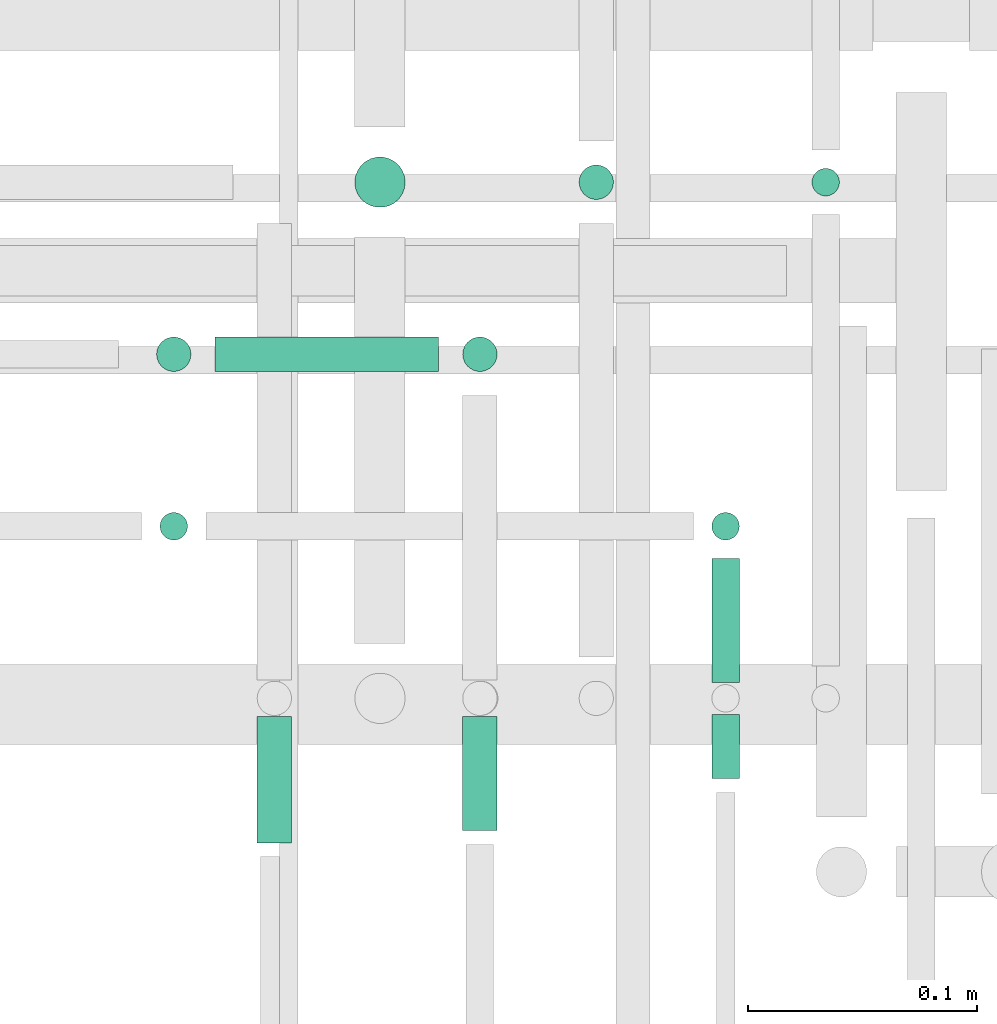
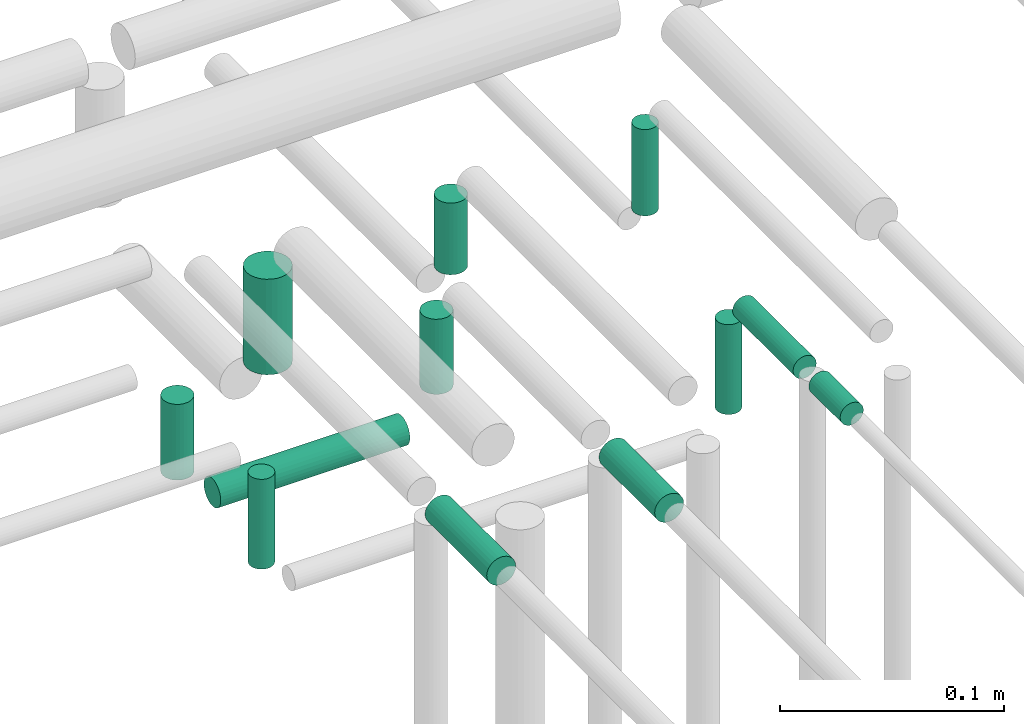
# One storey, part 298 of 331: 12 flow segments.
"""IFC2X3 building model written with IfcOpenShell, lengths in millimetres."""

from ifc_helpers import new_model, entity, si_unit, converted_unit, derived_unit, direction, frame, frame_2d, origin, origin_2d_with_axis, place, context, subcontext, project, spatial, circle, extrude, type_object, element, save


model = new_model("IFC2X3")

# Units and contexts
model_context = context("Model", 3, precision=0.01, world=origin(), true_north=direction((6.12303176911189e-17, 1.0)))
body_context = subcontext(model_context, "Body", "Model", "MODEL_VIEW")
ifc_project = project(units=[si_unit("LENGTHUNIT", "METRE", prefix="MILLI"), si_unit("AREAUNIT", "SQUARE_METRE"), si_unit("VOLUMEUNIT", "CUBIC_METRE"), converted_unit("PLANEANGLEUNIT", "DEGREE", entity("IfcRatioMeasure", 0.0174532925199433), si_unit("PLANEANGLEUNIT", "RADIAN"), dimensions=[0, 0, 0, 0, 0, 0, 0]), si_unit("MASSUNIT", "GRAM", prefix="KILO"), derived_unit("MASSDENSITYUNIT", [(si_unit("MASSUNIT", "GRAM", prefix="KILO"), 1), (si_unit("LENGTHUNIT", "METRE"), -3)]), derived_unit("MOMENTOFINERTIAUNIT", [(si_unit("LENGTHUNIT", "METRE"), 4)]), si_unit("TIMEUNIT", "SECOND"), si_unit("FREQUENCYUNIT", "HERTZ"), si_unit("THERMODYNAMICTEMPERATUREUNIT", "DEGREE_CELSIUS"), derived_unit("THERMALTRANSMITTANCEUNIT", [(si_unit("MASSUNIT", "GRAM", prefix="KILO"), 1), (si_unit("THERMODYNAMICTEMPERATUREUNIT", "KELVIN"), -1), (si_unit("TIMEUNIT", "SECOND"), -3)]), derived_unit("VOLUMETRICFLOWRATEUNIT", [(si_unit("LENGTHUNIT", "METRE"), 3), (si_unit("TIMEUNIT", "SECOND"), -1)]), derived_unit("MASSFLOWRATEUNIT", [(si_unit("MASSUNIT", "GRAM", prefix="KILO"), 1), (si_unit("TIMEUNIT", "SECOND"), -1)]), derived_unit("ROTATIONALFREQUENCYUNIT", [(si_unit("TIMEUNIT", "SECOND"), -1)]), si_unit("ELECTRICCURRENTUNIT", "AMPERE"), si_unit("ELECTRICVOLTAGEUNIT", "VOLT"), si_unit("POWERUNIT", "WATT"), si_unit("FORCEUNIT", "NEWTON", prefix="KILO"), si_unit("ILLUMINANCEUNIT", "LUX"), si_unit("LUMINOUSFLUXUNIT", "LUMEN"), si_unit("LUMINOUSINTENSITYUNIT", "CANDELA"), derived_unit("USERDEFINED", [(si_unit("MASSUNIT", "GRAM", prefix="KILO"), -1), (si_unit("LENGTHUNIT", "METRE"), -2), (si_unit("TIMEUNIT", "SECOND"), 3), (si_unit("LUMINOUSFLUXUNIT", "LUMEN"), 1)]), derived_unit("LINEARVELOCITYUNIT", [(si_unit("LENGTHUNIT", "METRE"), 1), (si_unit("TIMEUNIT", "SECOND"), -1)]), si_unit("PRESSUREUNIT", "PASCAL"), derived_unit("USERDEFINED", [(si_unit("LENGTHUNIT", "METRE"), -2), (si_unit("MASSUNIT", "GRAM", prefix="KILO"), 1), (si_unit("TIMEUNIT", "SECOND"), -2)]), derived_unit("LINEARFORCEUNIT", [(si_unit("MASSUNIT", "GRAM", prefix="KILO"), 1), (si_unit("LENGTHUNIT", "METRE"), 1), (si_unit("TIMEUNIT", "SECOND"), -2), (si_unit("LENGTHUNIT", "METRE"), -1)]), derived_unit("PLANARFORCEUNIT", [(si_unit("MASSUNIT", "GRAM", prefix="KILO"), 1), (si_unit("LENGTHUNIT", "METRE"), 1), (si_unit("TIMEUNIT", "SECOND"), -2), (si_unit("LENGTHUNIT", "METRE"), -2)])], contexts=[model_context])

# Site, building, storey
site_placement = place(None, frame((0.0, -0.00077364408347762, 0.0)))
site = spatial("IfcSite", under=ifc_project, at=site_placement, CompositionType="ELEMENT")
building_placement = place(site_placement, origin())
building = spatial("IfcBuilding", under=site, at=building_placement, CompositionType="ELEMENT")
storey_placement = place(building_placement, origin())
storey = spatial("IfcBuildingStorey", under=building, at=storey_placement, CompositionType="ELEMENT", Elevation=0.0)

# Flow segments
pipe_segment_type = type_object("IfcPipeSegmentType", PredefinedType="NOTDEFINED")
flow_segment_1_placement = place(storey_placement, frame((63502.5166110417, 8368.02529159144, 14489.0)))
element("IfcFlowSegment", 1, at=flow_segment_1_placement, inside=storey, type_object=pipe_segment_type, context=body_context, shape_type="SweptSolid", body=[
    extrude(circle(Radius=6.0, at=frame_2d((0.0, 1.08286712929839e-12), x_axis=(1.0, 0.0))), frame((7.59527223591454, 7.5952722359167, 0.0), z_axis=(0.0, 0.0, 1.0), x_axis=(-1.0, 0.0, 0.0)), (0.0, 0.0, 1.0), 47.0000000000153),
])
flow_segment_2_placement = place(storey_placement, frame((63458.8735189448, 8157.62056382736, 14542.4047277641)))
element("IfcFlowSegment", 2, at=flow_segment_2_placement, inside=storey, type_object=pipe_segment_type, context=body_context, shape_type="SweptSolid", body=[
    extrude(circle(Radius=6.0, at=origin_2d_with_axis()), frame((7.59527223591454, 0.0, 7.5952722359167), z_axis=(0.0, 1.0, 0.0), x_axis=(-1.0, 0.0, 0.0)), (0.0, 0.0, 1.0), 53.9999999999996),
])
flow_segment_3_placement = place(storey_placement, frame((63458.8735189448, 8115.62056382737, 14542.4047277641)))
element("IfcFlowSegment", 3, at=flow_segment_3_placement, inside=storey, type_object=pipe_segment_type, context=body_context, shape_type="SweptSolid", body=[
    extrude(circle(Radius=6.0, at=frame_2d((-8.66293703438714e-12, 0.0), x_axis=(1.0, 0.0))), frame((7.5952722359232, 0.0, 7.5952722359167), z_axis=(0.0, 1.0, 0.0), x_axis=(-1.0, 0.0, 0.0)), (0.0, 0.0, 1.0), 27.9999999999828),
])
flow_segment_4_placement = place(storey_placement, frame((63218.3298174384, 8218.02529159144, 14487.090264591)))
element("IfcFlowSegment", 4, at=flow_segment_4_placement, inside=storey, type_object=pipe_segment_type, context=body_context, shape_type="SweptSolid", body=[
    extrude(circle(Radius=6.0, at=origin_2d_with_axis()), frame((7.59527223591454, 7.59527223591562, 0.0)), (0.0, 0.0, 1.0), 48.9097354090115),
])
flow_segment_5_placement = place(storey_placement, frame((63458.8735189448, 8218.02529159144, 14487.090264591)))
element("IfcFlowSegment", 5, at=flow_segment_5_placement, inside=storey, type_object=pipe_segment_type, context=body_context, shape_type="SweptSolid", body=[
    extrude(circle(Radius=6.0, at=origin_2d_with_axis()), frame((7.59527223591454, 7.59527223591562, 0.0)), (0.0, 0.0, 1.0), 48.9097354090028),
])
flow_segment_6_placement = place(storey_placement, frame((63401.0132627126, 8366.52529159144, 14493.0)))
element("IfcFlowSegment", 6, at=flow_segment_6_placement, inside=storey, type_object=pipe_segment_type, context=body_context, shape_type="SweptSolid", body=[
    extrude(circle(Radius=7.5, at=origin_2d_with_axis()), frame((9.09527223591419, 9.09527223591636, 0.0), z_axis=(0.0, 0.0, 1.0), x_axis=(-1.0, 0.0, 0.0)), (0.0, 0.0, 1.0), 39.0000000000344),
])
flow_segment_7_placement = place(storey_placement, frame((63350.2906839002, 8093.00994384938, 14540.9047277641)))
element("IfcFlowSegment", 7, at=flow_segment_7_placement, inside=storey, type_object=pipe_segment_type, context=body_context, shape_type="SweptSolid", body=[
    extrude(circle(Radius=7.5, at=frame_2d((-8.66293703438714e-12, 0.0), x_axis=(1.0, 0.0))), frame((9.09527223592286, 0.0, 9.09527223591636), z_axis=(0.0, 1.0, 0.0), x_axis=(-1.0, 0.0, 0.0)), (0.0, 0.0, 1.0), 49.6106199779774),
])
flow_segment_8_placement = place(storey_placement, frame((63350.2906839002, 8291.52529159144, 14491.090264591)))
element("IfcFlowSegment", 8, at=flow_segment_8_placement, inside=storey, type_object=pipe_segment_type, context=body_context, shape_type="SweptSolid", body=[
    extrude(circle(Radius=7.5, at=origin_2d_with_axis()), frame((9.09527223591419, 9.09527223591636, 0.0)), (0.0, 0.0, 1.0), 40.9097354090068),
])
flow_segment_9_placement = place(storey_placement, frame((63243.9250896743, 8291.52529159144, 14463.9949923551)))
element("IfcFlowSegment", 9, at=flow_segment_9_placement, inside=storey, type_object=pipe_segment_type, context=body_context, shape_type="SweptSolid", body=[
    extrude(circle(Radius=7.5, at=frame_2d((0.0, -2.16573425859679e-12), x_axis=(1.0, 0.0))), frame((0.0, 9.09527223591636, 9.09527223591853), z_axis=(1.0, 0.0, 0.0), x_axis=(0.0, 1.0, 0.0)), (0.0, 0.0, 1.0), 97.4608664618133),
])
flow_segment_10_placement = place(storey_placement, frame((63216.8298174384, 8291.52529159144, 14491.090264591)))
element("IfcFlowSegment", 10, at=flow_segment_10_placement, inside=storey, type_object=pipe_segment_type, context=body_context, shape_type="SweptSolid", body=[
    extrude(circle(Radius=7.5, at=origin_2d_with_axis()), frame((9.09527223591419, 9.09527223591636, 0.0), z_axis=(0.0, 0.0, 1.0), x_axis=(-1.0, 0.0, 0.0)), (0.0, 0.0, 1.0), 41.2975296723525),
])
flow_segment_11_placement = place(storey_placement, frame((63303.2157915365, 8363.02529159144, 14474.0)))
element("IfcFlowSegment", 11, at=flow_segment_11_placement, inside=storey, type_object=pipe_segment_type, context=body_context, shape_type="SweptSolid", body=[
    extrude(circle(Radius=11.0, at=origin_2d_with_axis()), frame((12.5952722359134, 12.5952722359156, 0.0), z_axis=(0.0, 0.0, 1.0), x_axis=(-1.0, 0.0, 0.0)), (0.0, 0.0, 1.0), 52.000000000012),
])
flow_segment_12_placement = place(storey_placement, frame((63260.6765027261, 8087.62056382734, 14541.2921403887)))
element("IfcFlowSegment", 12, at=flow_segment_12_placement, inside=storey, type_object=pipe_segment_type, context=body_context, shape_type="SweptSolid", body=[
    extrude(circle(Radius=7.5, at=origin_2d_with_axis()), frame((9.09527223591419, 0.0, 9.09527223591636), z_axis=(0.0, 1.0, 0.0), x_axis=(-1.0, 0.0, 0.0)), (0.0, 0.0, 1.0), 55.000000000007),
])

save(model, "model.ifc")
